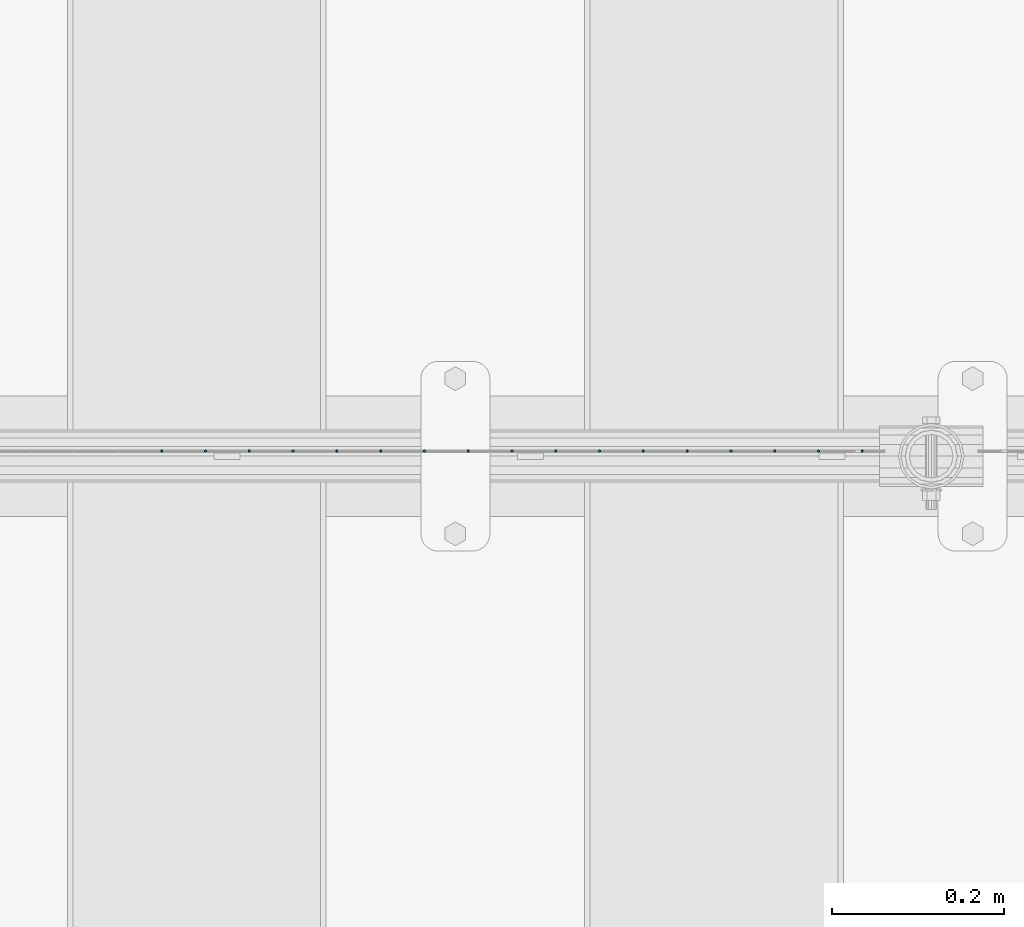
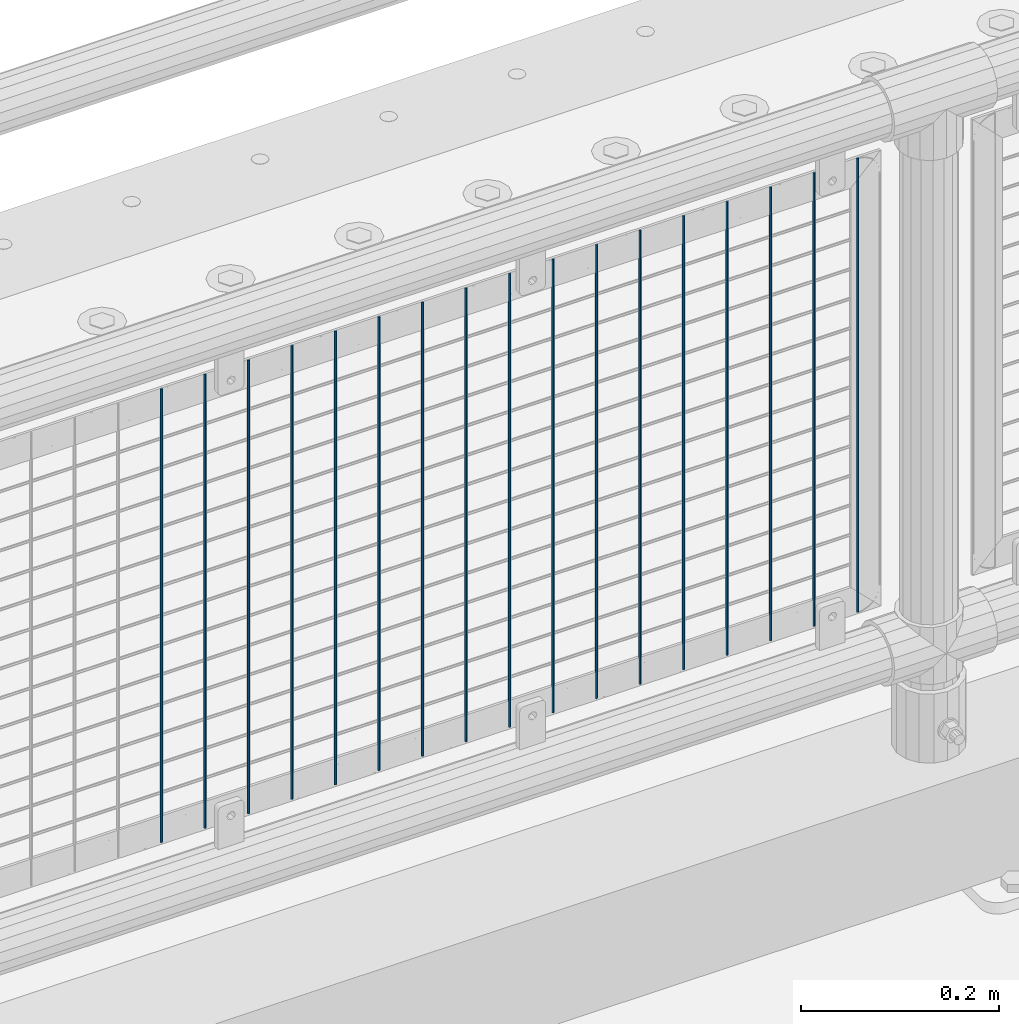
# One storey, part 86 of 242: 17 columns.
"""IFC2X3 building model written with IfcOpenShell, lengths in millimetres."""

import ifcopenshell
import ifcopenshell.guid

model = None  # the IFC model being written
_history = None  # IfcOwnerHistory: only IFC2X3 demands one
_inside = {}  # id of a spatial element -> (the spatial element, [elements in it])
_under = {}  # id of a project, library or spatial element -> (it, [spatial elements below it])
_declared = {}  # id of a project -> (the project, [libraries it declares])
_typed = {}  # id of a type object -> (the type object, [elements of that type])
_made_of = {}  # id of a material, layer set ... -> (it, [elements and type objects made of it])


def new_model(schema):
    """Start an empty IFC model of exactly this schema.

    Asked for "IFC4X3", IfcOpenShell would pick the latest addendum, in which some entities
    have other attributes; the version numbers below select the first issue.
    IFC2X3 requires an IfcOwnerHistory on every rooted entity: one is made here for all.
    """
    global model, _history
    if schema == "IFC4X3":
        model = ifcopenshell.file(schema_version=(4, 3, 0, 0))
    else:
        model = ifcopenshell.file(schema=schema)
    _inside.clear()
    _under.clear()
    _declared.clear()
    _typed.clear()
    _made_of.clear()
    _history = None
    if model.schema == "IFC2X3":
        org = make("IfcOrganization", Name="unknown")
        user = make(
            "IfcPersonAndOrganization",
            ThePerson=make("IfcPerson", FamilyName="unknown"),
            TheOrganization=org,
        )
        app = make(
            "IfcApplication",
            ApplicationDeveloper=org,
            Version="unknown",
            ApplicationFullName="unknown",
            ApplicationIdentifier="unknown",
        )
        _history = make(
            "IfcOwnerHistory",
            OwningUser=user,
            OwningApplication=app,
            ChangeAction="ADDED",
            CreationDate=0,
        )
    return model


def make(cls, **values):
    """One entity of the class cls with the attributes given. An attribute that is None is left unset."""
    return model.create_entity(
        cls, **{name: value for name, value in values.items() if value is not None}
    )


def rooted(cls, **values):
    """An entity with a GlobalId (a new one), such as an element, a storey or a relation."""
    return make(cls, GlobalId=ifcopenshell.guid.new(), OwnerHistory=_history, **values)


def si_unit(unit_type, name, prefix=None):
    """IfcSIUnit, for example si_unit("LENGTHUNIT", "METRE", prefix="MILLI")."""
    return make("IfcSIUnit", UnitType=unit_type, Prefix=prefix, Name=name)


def assignment(units):
    """IfcUnitAssignment: the units of a project."""
    return None if units is None else make("IfcUnitAssignment", Units=units)


def point(xyz):
    """IfcCartesianPoint."""
    return None if xyz is None else make("IfcCartesianPoint", Coordinates=xyz)


def direction(xyz):
    """IfcDirection."""
    return None if xyz is None else make("IfcDirection", DirectionRatios=xyz)


def frame(location, z_axis=None, x_axis=None):
    """IfcAxis2Placement3D, a coordinate frame: its origin and axes. An axis left out is left unset."""
    return make(
        "IfcAxis2Placement3D",
        Location=point(location),
        Axis=direction(z_axis),
        RefDirection=direction(x_axis),
    )


def origin_with_axes():
    """The frame at (0, 0, 0) with the z axis (0, 0, 1) and the x axis (1, 0, 0) written out."""
    return frame((0.0, 0.0, 0.0), z_axis=(0.0, 0.0, 1.0), x_axis=(1.0, 0.0, 0.0))


def place(relative_to, where):
    """IfcLocalPlacement: puts the frame where relative to a parent placement (None: the world)."""
    return make(
        "IfcLocalPlacement", PlacementRelTo=relative_to, RelativePlacement=where
    )


def context(
    kind, dimensions, precision=None, world=None, true_north=None, identifier=None
):
    """IfcGeometricRepresentationContext, for example the 3D "Model" context."""
    return make(
        "IfcGeometricRepresentationContext",
        ContextIdentifier=identifier,
        ContextType=kind,
        CoordinateSpaceDimension=dimensions,
        Precision=precision,
        WorldCoordinateSystem=world,
        TrueNorth=true_north,
    )


def subcontext(parent, identifier, kind, view, scale=None):
    """IfcGeometricRepresentationSubContext, for example "Body" below "Model"."""
    return make(
        "IfcGeometricRepresentationSubContext",
        ContextIdentifier=identifier,
        ContextType=kind,
        ParentContext=parent,
        TargetScale=scale,
        TargetView=view,
    )


def project(units=None, contexts=None):
    """IfcProject with its units and contexts."""
    return rooted(
        "IfcProject",
        Name="project",
        RepresentationContexts=contexts,
        UnitsInContext=assignment(units),
    )


def spatial(cls, under=None, at=None, **own):
    """A site, building, storey or space (cls), placed at a placement, below another one or the project."""
    s = rooted(cls, ObjectPlacement=at, **own)
    if under is not None:
        _under.setdefault(under.id(), (under, []))[1].append(s)
    return s


def faces_of(points, faces, orient=None, outer=None):
    """IfcFace entities. A face is a list of loops; a loop is a list of indices into points, from 0.

    orient and outer hold one flag for each loop. By default every Orientation is true, the
    first loop of a face is its IfcFaceOuterBound and the others are IfcFaceBound.
    """
    made = []
    for i, loops in enumerate(faces):
        bounds = []
        for j, loop in enumerate(loops):
            is_outer = j == 0 if outer is None else outer[i][j]
            bounds.append(
                make(
                    "IfcFaceOuterBound" if is_outer else "IfcFaceBound",
                    Bound=make("IfcPolyLoop", Polygon=[points[k] for k in loop]),
                    Orientation=True if orient is None else orient[i][j],
                )
            )
        made.append(make("IfcFace", Bounds=bounds))
    return made


def faceted_brep(points, faces, orient=None, outer=None, voids=None):
    """IfcFacetedBrep: a solid bounded by flat faces; with voids (closed shells), ...WithVoids."""
    shared = [point(p) for p in points]
    hull = make("IfcClosedShell", CfsFaces=faces_of(shared, faces, orient, outer))
    if voids is None:
        return make("IfcFacetedBrep", Outer=hull)
    return make(
        "IfcFacetedBrepWithVoids",
        Outer=hull,
        Voids=[
            make(cls, CfsFaces=faces_of(shared, fs, o, b)) for cls, fs, o, b in voids
        ],
    )


def shape(context_of_items, identifier, shape_type, items):
    """IfcShapeRepresentation: the items that make up one representation, for example the "Body"."""
    return make(
        "IfcShapeRepresentation",
        ContextOfItems=context_of_items,
        RepresentationIdentifier=identifier,
        RepresentationType=shape_type,
        Items=items,
    )


def material(Name=None, Category=None):
    """IfcMaterial."""
    return make("IfcMaterial", Name=Name, Category=Category)


def made_of(thing, what):
    """Note that an element or type object is made of a material, layer set ...; save() writes the relation."""
    if what is not None:
        _made_of.setdefault(what.id(), (what, []))[1].append(thing)
    return thing


def type_object(cls, material=None, **own):
    """A type object (cls), such as IfcWallType, which elements share."""
    return made_of(rooted(cls, **own), material)


def element(
    cls,
    number,
    at=None,
    inside=None,
    cuts=None,
    type_object=None,
    material=None,
    context=None,
    identifier="Body",
    shape_type=None,
    held_by="IfcProductDefinitionShape",
    body=None,
    shapes=None,
    **own,
):
    """One element of the class cls, such as IfcWall. Its Tag is "e" and its number.

    at: its placement. inside: the storey or other place that contains it. cuts: it is an
    opening in that element (IfcRelVoidsElement). A single representation is given by context,
    identifier, shape_type and body (its items); several are given by shapes. held_by: the class
    of the entity that holds the representations. save() writes the other relations.
    """
    e = rooted(cls, Tag="e%d" % number, ObjectPlacement=at, **own)
    if body is not None:
        shapes = [shape(context, identifier, shape_type, body)]
    if shapes is not None:
        e.Representation = make(held_by, Representations=shapes)
    if inside is not None:
        _inside.setdefault(inside.id(), (inside, []))[1].append(e)
    if cuts is not None:
        rooted(
            "IfcRelVoidsElement", RelatingBuildingElement=cuts, RelatedOpeningElement=e
        )
    if type_object is not None:
        _typed.setdefault(type_object.id(), (type_object, []))[1].append(e)
    return made_of(e, material)


def aggregate(whole, parts):
    """IfcRelAggregates: a whole, such as a stair, and the parts it consists of."""
    return rooted("IfcRelAggregates", RelatingObject=whole, RelatedObjects=parts)


def save(model, path):
    """Write the relations noted so far, then the file.

    IfcRelAggregates (storeys below a building ...), IfcRelContainedInSpatialStructure (elements
    in a storey), IfcRelDefinesByType, IfcRelAssociatesMaterial and IfcRelDeclares: one each for
    every whole, place, type object, material and project.
    """
    for whole, parts in _under.values():
        aggregate(whole, parts)
    for where, things in _inside.values():
        rooted(
            "IfcRelContainedInSpatialStructure",
            RelatedElements=things,
            RelatingStructure=where,
        )
    for kind, things in _typed.values():
        rooted("IfcRelDefinesByType", RelatedObjects=things, RelatingType=kind)
    for what, things in _made_of.values():
        rooted("IfcRelAssociatesMaterial", RelatedObjects=things, RelatingMaterial=what)
    for by, libraries in _declared.values():
        rooted("IfcRelDeclares", RelatingContext=by, RelatedDefinitions=libraries)
    model.write(path)


model = new_model("IFC2X3")

# Units and contexts
model_context = context("Model", 3, precision=1e-05, world=origin_with_axes())
body_context = subcontext(model_context, "Body", "Model", "MODEL_VIEW")
ifc_project = project(units=[si_unit("LENGTHUNIT", "METRE", prefix="MILLI"), si_unit("AREAUNIT", "SQUARE_METRE"), si_unit("VOLUMEUNIT", "CUBIC_METRE"), si_unit("MASSUNIT", "GRAM", prefix="KILO"), si_unit("TIMEUNIT", "SECOND"), si_unit("PLANEANGLEUNIT", "RADIAN"), si_unit("SOLIDANGLEUNIT", "STERADIAN"), si_unit("THERMODYNAMICTEMPERATUREUNIT", "DEGREE_CELSIUS"), si_unit("LUMINOUSINTENSITYUNIT", "LUMEN")], contexts=[model_context])

# Site, building, storey
site_placement = place(None, origin_with_axes())
site = spatial("IfcSite", under=ifc_project, at=site_placement, CompositionType="ELEMENT")
building_placement = place(site_placement, origin_with_axes())
building = spatial("IfcBuilding", under=site, at=building_placement, Name="Standard", CompositionType="ELEMENT")
storey_placement = place(building_placement, origin_with_axes())
storey = spatial("IfcBuildingStorey", under=building, at=storey_placement, Name="Undefined", CompositionType="ELEMENT", Elevation=0.0)

# Columns
ifc_material = material(Name="Misc_Undefined")
column_type = type_object("IfcColumnType", Name="D3", PredefinedType="NOTDEFINED")
for number, where, z_axis, x_axis in (
    (1, (-30528.796, -19329.5, 353.02), (-1.0, 0.0, 0.0), (0.0, 0.0, 1.0)),
    (2, (-30579.589, -19329.5, 353.02), (-1.0, 0.0, 0.0), (0.0, 0.0, 1.0)),
    (3, (-30630.382, -19329.5, 353.02), (-1.0, 0.0, 0.0), (0.0, 0.0, 1.0)),
    (4, (-30681.175, -19329.5, 353.02), (-1.0, 0.0, 0.0), (0.0, 0.0, 1.0)),
    (5, (-30731.968, -19329.5, 353.02), (-1.0, 0.0, 0.0), (0.0, 0.0, 1.0)),
    (6, (-30782.761, -19329.5, 353.02), (-1.0, 0.0, 0.0), (0.0, 0.0, 1.0)),
    (7, (-30833.554, -19329.5, 353.02), (-1.0, 0.0, 0.0), (0.0, 0.0, 1.0)),
    (8, (-30478.003, -19329.5, 353.02), (-1.0, 0.0, 0.0), (0.0, 0.0, 1.0)),
    (9, (-30884.347, -19329.5, 353.02), (-1.0, 0.0, 0.0), (0.0, 0.0, 1.0)),
    (10, (-30935.14, -19329.5, 353.02), (-1.0, 0.0, 0.0), (0.0, 0.0, 1.0)),
    (11, (-30985.933, -19329.5, 353.02), (-1.0, 0.0, 0.0), (0.0, 0.0, 1.0)),
    (12, (-31036.726, -19329.5, 353.02), (-1.0, 0.0, 0.0), (0.0, 0.0, 1.0)),
    (13, (-31087.519, -19329.5, 353.02), (-1.0, 0.0, 0.0), (0.0, 0.0, 1.0)),
    (14, (-31138.312, -19329.5, 353.02), (-1.0, 0.0, 0.0), (0.0, 0.0, 1.0)),
    (15, (-31189.105, -19329.5, 353.02), (-1.0, 0.0, 0.0), (0.0, 0.0, 1.0)),
    (16, (-31239.898, -19329.5, 353.02), (-1.0, 0.0, 0.0), (0.0, 0.0, 1.0)),
    (17, (-31290.691, -19329.5, 353.02), (-1.0, 0.0, 0.0), (0.0, 0.0, 1.0)),
):
    element("IfcColumn", number, at=place(storey_placement, frame(where, z_axis=z_axis, x_axis=x_axis)), inside=storey, type_object=column_type, material=ifc_material, ObjectType="D3", context=body_context, shape_type="Brep", body=[
        faceted_brep([(0.0, -1.50000000000364, 0.0), (-3.63797880709171e-12, -0.750000000003638, -1.29903810567669), (560.0, -0.75, -1.29903810567703), (560.0, -1.5, 0.0), (0.0, 0.749999999996362, -1.29903810567669), (560.0, 0.75, -1.29903810567703), (-3.63797880709171e-12, 1.49999999999636, 0.0), (560.0, 1.5, 0.0), (0.0, 0.749999999996362, 1.29903810567669), (560.0, 0.75, 1.29903810567703), (-3.63797880709171e-12, -0.750000000003638, 1.29903810567669), (560.0, -0.75, 1.29903810567703)], [[[0, 1, 2, 3]], [[1, 4, 5, 2]], [[4, 6, 7, 5]], [[6, 8, 9, 7]], [[8, 10, 11, 9]], [[10, 0, 3, 11]], [[5, 7, 9, 11, 3, 2]], [[10, 8, 6, 4, 1, 0]]]),
    ])

save(model, "model.ifc")
